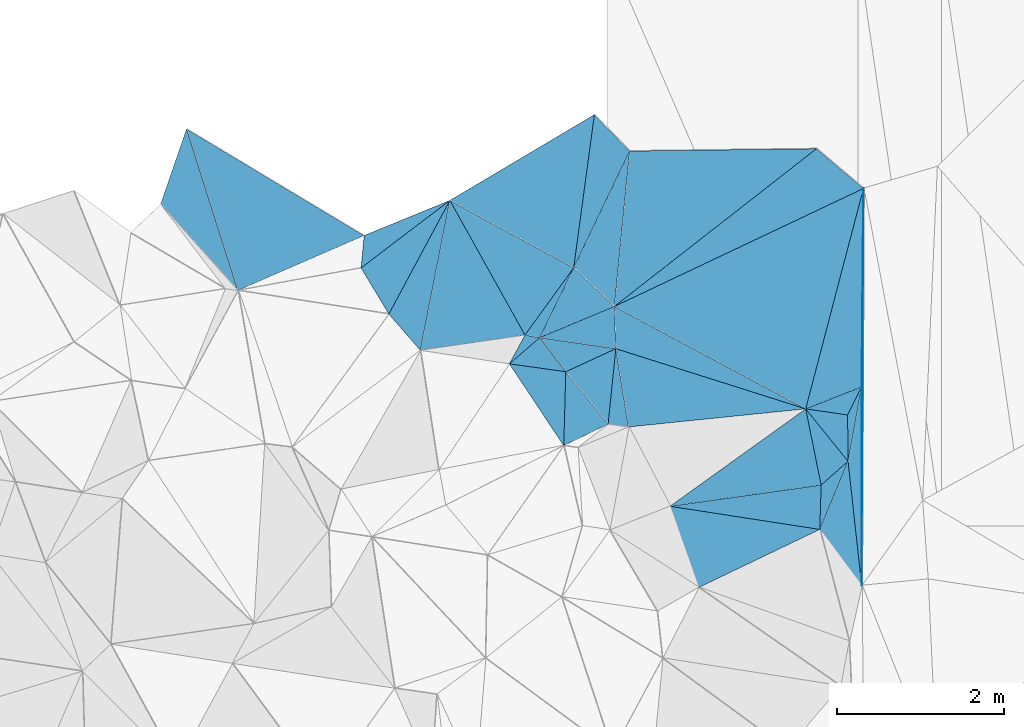
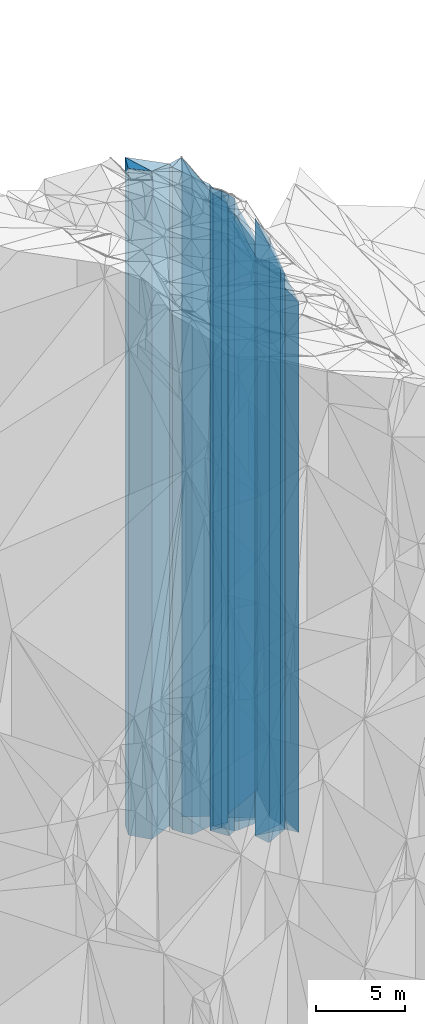
# One storey, part 273 of 275: 37 plates.
"""IFC2X3 building model written with IfcOpenShell, lengths in millimetres."""

from ifc_helpers import new_model, si_unit, frame, origin_with_axes, place, context, subcontext, project, spatial, faceted_brep, material, type_object, element, save


model = new_model("IFC2X3")

# Units and contexts
model_context = context("Model", 3, precision=1e-05, world=origin_with_axes())
body_context = subcontext(model_context, "Body", "Model", "MODEL_VIEW")
ifc_project = project(units=[si_unit("LENGTHUNIT", "METRE", prefix="MILLI"), si_unit("AREAUNIT", "SQUARE_METRE"), si_unit("VOLUMEUNIT", "CUBIC_METRE"), si_unit("MASSUNIT", "GRAM", prefix="KILO"), si_unit("TIMEUNIT", "SECOND"), si_unit("PLANEANGLEUNIT", "RADIAN"), si_unit("SOLIDANGLEUNIT", "STERADIAN"), si_unit("THERMODYNAMICTEMPERATUREUNIT", "DEGREE_CELSIUS"), si_unit("LUMINOUSINTENSITYUNIT", "LUMEN")], contexts=[model_context])

# Site, building, storey
site_placement = place(None, origin_with_axes())
site = spatial("IfcSite", under=ifc_project, at=site_placement, CompositionType="ELEMENT")
building_placement = place(site_placement, origin_with_axes())
building = spatial("IfcBuilding", under=site, at=building_placement, Name="Undefined", CompositionType="ELEMENT")
storey_placement = place(building_placement, origin_with_axes())
storey = spatial("IfcBuildingStorey", under=building, at=storey_placement, Name="Undefined", CompositionType="ELEMENT", Elevation=0.0)

# Plates
ifc_material = material()
plate_type_1 = type_object("IfcPlateType", PredefinedType="NOTDEFINED")
plate_1_placement = place(storey_placement, frame((-98121.5474318515, 131950.732963402, 26824.0), z_axis=(-0.999534183592398, 0.0305191059875469, 0.0), x_axis=(0.0305191059875562, 0.999534183592397, 0.0)))
element("IfcPlate", 1, at=plate_1_placement, inside=storey, type_object=plate_type_1, material=ifc_material, Name="00", context=body_context, shape_type="Brep", body=[
    faceted_brep([(1.45519152283669e-11, -18996.0, 0.0), (222.635833740249, -23306.0, 1803.25634765625), (222.635833740249, 18996.0, 1803.25634765625), (1.45519152283669e-11, 18996.0, 0.0), (532.259338378906, -19006.0, -1.03318598121405e-09), (532.259338378906, 18996.0, -1.03318598121405e-09)], [[[0, 1, 2, 3]], [[1, 4, 5, 2]], [[4, 0, 3, 5]], [[5, 3, 2]], [[4, 1, 0]]]),
])
plate_type_2 = type_object("IfcPlateType", PredefinedType="NOTDEFINED")
plate_2_placement = place(storey_placement, frame((-98121.5474318515, 131950.732963402, 26824.0), z_axis=(-0.152764910053811, -0.988262557348122, 0.0), x_axis=(-0.988262557348123, 0.152764910053806, 0.0)))
element("IfcPlate", 2, at=plate_2_placement, inside=storey, type_object=plate_type_2, material=ifc_material, Name="00", context=body_context, shape_type="Brep", body=[
    faceted_brep([(1.45519152283669e-11, -18996.0, 0.0), (1328.7667236328, -22476.0, 910.482849121094), (1328.7667236328, 18996.0, 910.482849121094), (1.45519152283669e-11, 18996.0, 0.0), (1816.94799804688, -23306.0, 8.73114913702011e-11), (1816.94799804688, 18996.0, 8.73114913702011e-11)], [[[0, 1, 2, 3]], [[1, 4, 5, 2]], [[4, 0, 3, 5]], [[5, 3, 2]], [[4, 1, 0]]]),
])
plate_type_3 = type_object("IfcPlateType", PredefinedType="NOTDEFINED")
plate_3_placement = place(storey_placement, frame((-101166.01981522, 133841.020747551, 29644.0), z_axis=(-0.138726250945665, -0.990330766612126, 0.0), x_axis=(-0.990330766612127, 0.138726250945655, 0.0)))
element("IfcPlate", 3, at=plate_3_placement, inside=storey, type_object=plate_type_3, material=ifc_material, Name="00", context=body_context, shape_type="Brep", body=[
    faceted_brep([(0.0, -21816.0, -2.18278728425503e-11), (-99.0270233154297, -22096.0, 880.110046386733), (-99.0270233154297, 21816.0, 880.110046386733), (-1.45519152283669e-11, 21816.0, 1.45519152283669e-11), (682.641906738296, -22166.0, 4.43833414465189e-09), (682.641906738296, 21816.0, 4.43833414465189e-09)], [[[0, 1, 2, 3]], [[1, 4, 5, 2]], [[4, 0, 3, 5]], [[5, 3, 2]], [[4, 1, 0]]]),
])
plate_type_4 = type_object("IfcPlateType", PredefinedType="NOTDEFINED")
plate_4_placement = place(storey_placement, frame((-99917.1690995878, 132228.298858922, 26829.0), z_axis=(-0.139068254049693, 0.990282798353869, 0.0), x_axis=(0.990282798353869, 0.139068254049695, 0.0)))
element("IfcPlate", 4, at=plate_4_placement, inside=storey, type_object=plate_type_4, material=ifc_material, Name="00", context=body_context, shape_type="Brep", body=[
    faceted_brep([(-1.45519152283669e-11, -23301.0, 2.91038304567337e-11), (1773.3497314453, -19031.0, 930.0166015625), (1773.3497314453, 19001.0, 930.0166015625), (-1.45519152283669e-11, 19001.0, 2.91038304567337e-11), (1829.64477539061, -19001.0, -7.71251507103443e-09), (1829.64477539061, 19001.0, -7.71251507103443e-09)], [[[0, 1, 2, 3]], [[1, 4, 5, 2]], [[4, 0, 3, 5]], [[5, 3, 2]], [[4, 1, 0]]]),
])
plate_type_5 = type_object("IfcPlateType", PredefinedType="NOTDEFINED")
plate_5_placement = place(storey_placement, frame((-97782.8954813974, 132767.442738324, 26069.0), z_axis=(0.661910276065905, -0.749583075074643, 0.0), x_axis=(-0.749583075074636, -0.661910276065912, 0.0)))
element("IfcPlate", 5, at=plate_5_placement, inside=storey, type_object=plate_type_5, material=ifc_material, Name="00", context=body_context, shape_type="Brep", body=[
    faceted_brep([(2.91038304567337e-11, -18241.0, -1.45519152283669e-11), (794.436340332033, -19751.0, 388.034606933594), (794.436340332033, 18241.0, 388.034606933594), (0.0, 18241.0, 0.0), (430.116271972644, -19761.0, 5.79166226089001e-09), (430.116271972644, 18241.0, 5.79166226089001e-09)], [[[0, 1, 2, 3]], [[1, 4, 5, 2]], [[4, 0, 3, 5]], [[5, 3, 2]], [[4, 1, 0]]]),
])
plate_type_6 = type_object("IfcPlateType", PredefinedType="NOTDEFINED")
plate_6_placement = place(storey_placement, frame((-97782.8954813974, 132767.442738324, 26069.0), z_axis=(-0.999958933344225, -0.00906265000312683, 0.0), x_axis=(-0.00906265000311493, 0.999958933344225, 0.0)))
element("IfcPlate", 6, at=plate_6_placement, inside=storey, type_object=plate_type_6, material=ifc_material, Name="00", context=body_context, shape_type="Brep", body=[
    faceted_brep([(2.91038304567337e-11, -18241.0, -1.45519152283669e-11), (633.025634765625, -19791.0, 501.775421142593), (633.025634765625, 18241.0, 501.775421142593), (0.0, 18241.0, 0.0), (555.427734375029, -18321.0, -2.9394868761301e-09), (555.427734375029, 18241.0, -2.9394868761301e-09)], [[[0, 1, 2, 3]], [[1, 4, 5, 2]], [[4, 0, 3, 5]], [[5, 3, 2]], [[4, 1, 0]]]),
])
plate_type_7 = type_object("IfcPlateType", PredefinedType="NOTDEFINED")
plate_7_placement = place(storey_placement, frame((-98121.5474318515, 131950.732963402, 25978.0), z_axis=(0.801619117841387, 0.597835085881714, 0.0), x_axis=(0.597835085881705, -0.801619117841394, 0.0)))
element("IfcPlate", 7, at=plate_7_placement, inside=storey, type_object=plate_type_7, material=ifc_material, Name="00", context=body_context, shape_type="Brep", body=[
    faceted_brep([(-2.91038304567337e-11, -19842.0, 5.74118530494161e-12), (-452.232147216826, -18332.0, 759.727661132818), (-452.232147216826, 18150.0, 759.727661132818), (1.45519152283669e-11, 18150.0, 1.45519152283669e-11), (840.077392578067, -18150.0, -1.20206777864951e-09), (840.077392578067, 18150.0, -1.20206777864951e-09)], [[[0, 1, 2, 3]], [[1, 4, 5, 2]], [[4, 0, 3, 5]], [[5, 3, 2]], [[4, 1, 0]]]),
])
plate_type_8 = type_object("IfcPlateType", PredefinedType="NOTDEFINED")
plate_8_placement = place(storey_placement, frame((-100566.438423901, 134117.068126065, 28964.0), z_axis=(0.994857020313297, -0.101289235031902, 0.0), x_axis=(-0.101289235031895, -0.994857020313298, 0.0)))
element("IfcPlate", 8, at=plate_8_placement, inside=storey, type_object=plate_type_8, material=ifc_material, Name="00", context=body_context, shape_type="Brep", body=[
    faceted_brep([(2.91038304567337e-11, -21136.0, 1.45519152283669e-11), (918.194641113267, -21376.0, 246.817047119141), (918.194641113267, 21136.0, 246.817047119141), (-7.27595761418343e-12, 21136.0, 0.0), (909.175476074219, -22166.0, 5.02041075378656e-09), (909.175476074219, 21136.0, 5.02041075378656e-09)], [[[0, 1, 2, 3]], [[1, 4, 5, 2]], [[4, 0, 3, 5]], [[5, 3, 2]], [[4, 1, 0]]]),
])
plate_type_9 = type_object("IfcPlateType", PredefinedType="NOTDEFINED")
plate_9_placement = place(storey_placement, frame((-100566.438423901, 134117.068126065, 28964.0), z_axis=(0.418205603024499, -0.908352395053217, 0.0), x_axis=(-0.908352395053213, -0.418205603024508, 0.0)))
element("IfcPlate", 9, at=plate_9_placement, inside=storey, type_object=plate_type_9, material=ifc_material, Name="00", context=body_context, shape_type="Brep", body=[
    faceted_brep([(2.91038304567337e-11, -21136.0, 1.45519152283669e-11), (461.916687011711, -22166.0, 783.091918945283), (461.916687011711, 21136.0, 783.091918945283), (-7.27595761418343e-12, 21136.0, 0.0), (660.075744628914, -22496.0, 2.61934474110603e-09), (660.075744628914, 21136.0, 2.61934474110603e-09)], [[[0, 1, 2, 3]], [[1, 4, 5, 2]], [[4, 0, 3, 5]], [[5, 3, 2]], [[4, 1, 0]]]),
])
plate_type_10 = type_object("IfcPlateType", PredefinedType="NOTDEFINED")
plate_10_placement = place(storey_placement, frame((-100658.52811006, 133212.568546351, 29479.0), z_axis=(-0.778004293593025, -0.628258958671357, 0.0), x_axis=(-0.62825895867135, 0.778004293593031, 0.0)))
element("IfcPlate", 10, at=plate_10_placement, inside=storey, type_object=plate_type_10, material=ifc_material, Name="00", context=body_context, shape_type="Brep", body=[
    faceted_brep([(-2.91038304567337e-11, -21651.0, 7.27595761418343e-12), (134.072036743135, -22261.0, 574.912780761726), (134.072036743135, 21651.0, 574.912780761726), (-2.91038304567337e-11, 21651.0, 7.27595761418343e-12), (807.774719238252, -21981.0, -2.85945134237409e-09), (807.774719238252, 21651.0, -2.85945134237409e-09)], [[[0, 1, 2, 3]], [[1, 4, 5, 2]], [[4, 0, 3, 5]], [[5, 3, 2]], [[4, 1, 0]]]),
])
plate_type_11 = type_object("IfcPlateType", PredefinedType="NOTDEFINED")
plate_11_placement = place(storey_placement, frame((-97619.7549121552, 133659.622739595, 26009.0), z_axis=(0.894653739119455, -0.446760212059645, 0.0), x_axis=(-0.446760212059642, -0.894653739119456, 0.0)))
element("IfcPlate", 11, at=plate_11_placement, inside=storey, type_object=plate_type_11, material=ifc_material, Name="00", context=body_context, shape_type="Brep", body=[
    faceted_brep([(1.45519152283669e-11, -18181.0, -2.91038304567337e-11), (871.07690429689, -18301.0, 252.636199951143), (871.07690429689, 18181.0, 252.636199951143), (1.45519152283669e-11, 18181.0, -2.91038304567337e-11), (376.430603027358, -18381.0, -3.28873284161091e-09), (376.430603027358, 18181.0, -3.28873284161091e-09)], [[[0, 1, 2, 3]], [[1, 4, 5, 2]], [[4, 0, 3, 5]], [[5, 3, 2]], [[4, 1, 0]]]),
])
plate_type_12 = type_object("IfcPlateType", PredefinedType="NOTDEFINED")
plate_12_placement = place(storey_placement, frame((-100582.733736698, 134623.757836619, 26844.0), z_axis=(0.999483257120555, 0.0321437200038698, 0.0), x_axis=(0.0321437200038842, -0.999483257120554, 0.0)))
element("IfcPlate", 12, at=plate_12_placement, inside=storey, type_object=plate_type_12, material=ifc_material, Name="00", context=body_context, shape_type="Brep", body=[
    faceted_brep([(-2.91038304567337e-11, -23306.0, -1.45519152283669e-11), (1300.91296386713, -19016.0, 2251.69384765625), (1300.91296386713, 19016.0, 2251.69384765625), (0.0, 19016.0, -2.91038304567337e-11), (506.951660156221, -23256.0, -1.25146470963955e-09), (506.951660156221, 19016.0, -1.25146470963955e-09)], [[[0, 1, 2, 3]], [[1, 4, 5, 2]], [[4, 0, 3, 5]], [[5, 3, 2]], [[4, 1, 0]]]),
])
plate_type_13 = type_object("IfcPlateType", PredefinedType="NOTDEFINED")
plate_13_placement = place(storey_placement, frame((-97782.8954813974, 132767.442738324, 25978.0), z_axis=(0.994028888740654, 0.10911722297154, 0.0), x_axis=(0.109117222971529, -0.994028888740655, 0.0)))
element("IfcPlate", 13, at=plate_13_placement, inside=storey, type_object=plate_type_13, material=ifc_material, Name="00", context=body_context, shape_type="Brep", body=[
    faceted_brep([(-2.91038304567337e-11, -18332.0, 0.0), (-869.051269531279, -18212.0, 259.518646240234), (-869.051269531279, 18150.0, 259.518646240234), (1.45519152283669e-11, 18150.0, 1.45519152283669e-11), (1499.08300781247, -18150.0, -5.45696821063757e-09), (1499.08300781247, 18150.0, -5.45696821063757e-09)], [[[0, 1, 2, 3]], [[1, 4, 5, 2]], [[4, 0, 3, 5]], [[5, 3, 2]], [[4, 1, 0]]]),
])
plate_type_14 = type_object("IfcPlateType", PredefinedType="NOTDEFINED")
plate_14_placement = place(storey_placement, frame((-98290.3871865576, 133395.894939524, 26009.0), z_axis=(0.143867401977837, 0.989596973847509, 0.0), x_axis=(0.989596973847514, -0.143867401977803, 0.0)))
element("IfcPlate", 14, at=plate_14_placement, inside=storey, type_object=plate_type_14, material=ifc_material, Name="00", context=body_context, shape_type="Brep", body=[
    faceted_brep([(0.0, -19851.0, 2.91038304567337e-11), (625.713806152329, -18181.0, 357.466369628935), (625.713806152329, 18181.0, 357.466369628935), (1.45519152283669e-11, 18181.0, -2.91038304567337e-11), (507.740081787095, -18381.0, -2.60479282587767e-09), (507.740081787095, 18181.0, -2.60479282587767e-09)], [[[0, 1, 2, 3]], [[1, 4, 5, 2]], [[4, 0, 3, 5]], [[5, 3, 2]], [[4, 1, 0]]]),
])
plate_type_15 = type_object("IfcPlateType", PredefinedType="NOTDEFINED")
plate_15_placement = place(storey_placement, frame((-97598.4704620426, 136037.324144772, 26040.5), z_axis=(0.428078408955571, -0.903741597906208, 0.0), x_axis=(-0.903741597906208, -0.428078408955572, 0.0)))
element("IfcPlate", 15, at=plate_15_placement, inside=storey, type_object=plate_type_15, material=ifc_material, Name="00", context=body_context, shape_type="Brep", body=[
    faceted_brep([(-7.27595761418343e-12, -18212.5, 0.0), (1756.05273437498, -19819.5, 2090.9748535156), (1756.05273437498, 18212.5, 2090.9748535156), (-7.27595761418343e-12, 18212.5, 0.0), (3302.12011718749, -24109.5, -2.91038304567337e-08), (3302.12011718749, 18212.5, -2.91038304567337e-08)], [[[0, 1, 2, 3]], [[1, 4, 5, 2]], [[4, 0, 3, 5]], [[5, 3, 2]], [[4, 1, 0]]]),
])
plate_type_16 = type_object("IfcPlateType", PredefinedType="NOTDEFINED")
plate_16_placement = place(storey_placement, frame((-98105.3033525816, 132482.744363551, 26069.0), z_axis=(-0.661910276065905, 0.749583075074643, 0.0), x_axis=(0.749583075074651, 0.661910276065895, 0.0)))
element("IfcPlate", 16, at=plate_16_placement, inside=storey, type_object=plate_type_16, material=ifc_material, Name="00", context=body_context, shape_type="Brep", body=[
    faceted_brep([(7.27595761418343e-12, -19761.0, -2.91038304567337e-11), (465.688049316428, -19791.0, 806.991088867158), (465.688049316428, 18241.0, 806.991088867158), (0.0, 18241.0, 0.0), (430.116271972664, -18241.0, 5.73345459997654e-09), (430.116271972644, 18241.0, 5.79166226089001e-09)], [[[0, 1, 2, 3]], [[1, 4, 5, 2]], [[4, 0, 3, 5]], [[5, 3, 2]], [[4, 1, 0]]]),
])
plate_type_17 = type_object("IfcPlateType", PredefinedType="NOTDEFINED")
plate_17_placement = place(storey_placement, frame((-100566.438423901, 134117.068126065, 28964.0), z_axis=(-0.999483257120555, -0.0321437200038698, 0.0), x_axis=(-0.0321437200038805, 0.999483257120554, 0.0)))
element("IfcPlate", 17, at=plate_17_placement, inside=storey, type_object=plate_type_17, material=ifc_material, Name="00", context=body_context, shape_type="Brep", body=[
    faceted_brep([(2.91038304567337e-11, -21136.0, 1.45519152283669e-11), (161.948379516602, -22156.0, 906.792541503921), (161.948379516602, 21136.0, 906.792541503921), (-7.27595761418343e-12, 21136.0, 0.0), (506.95166015625, -21186.0, -1.22236087918282e-09), (506.95166015625, 21136.0, -1.22236087918282e-09)], [[[0, 1, 2, 3]], [[1, 4, 5, 2]], [[4, 0, 3, 5]], [[5, 3, 2]], [[4, 1, 0]]]),
])
plate_type_18 = type_object("IfcPlateType", PredefinedType="NOTDEFINED")
plate_18_placement = place(storey_placement, frame((-100413.893981991, 133178.595860496, 26844.0), z_axis=(-0.101798692024404, 0.994805019238504, 0.0), x_axis=(0.994805019238504, 0.101798692024408, 0.0)))
element("IfcPlate", 18, at=plate_18_placement, inside=storey, type_object=plate_type_18, material=ifc_material, Name="00", context=body_context, shape_type="Brep", body=[
    faceted_brep([(-1.45519152283669e-11, -23496.0, -2.91038304567337e-11), (-56.2167282104492, -23256.0, 949.125732421933), (-56.2167282104492, 19016.0, 949.125732421933), (0.0, 19016.0, -2.91038304567337e-11), (2134.59594726564, -19016.0, 5.355104804039e-09), (2134.59594726563, 19016.0, 5.29689714312553e-09)], [[[0, 1, 2, 3]], [[1, 4, 5, 2]], [[4, 0, 3, 5]], [[5, 3, 2]], [[4, 1, 0]]]),
])
plate_type_19 = type_object("IfcPlateType", PredefinedType="NOTDEFINED")
plate_19_placement = place(storey_placement, frame((-101071.251231754, 135085.656805035, 29184.0), z_axis=(0.809292046734251, -0.587406488807102, 0.0), x_axis=(-0.5874064888071, -0.809292046734252, 0.0)))
element("IfcPlate", 19, at=plate_19_placement, inside=storey, type_object=plate_type_19, material=ifc_material, Name="00", context=body_context, shape_type="Brep", body=[
    faceted_brep([(0.0, -21356.0, 0.0), (915.372375488289, -21936.0, 161.843780517578), (915.372375488289, 21356.0, 161.843780517578), (0.0, 21356.0, 0.0), (994.786437988274, -22146.0, 8.78935679793358e-09), (994.786437988274, 21356.0, 8.78935679793358e-09)], [[[0, 1, 2, 3]], [[1, 4, 5, 2]], [[4, 0, 3, 5]], [[5, 3, 2]], [[4, 1, 0]]]),
])
plate_type_20 = type_object("IfcPlateType", PredefinedType="NOTDEFINED")
plate_20_placement = place(storey_placement, frame((-100566.438423901, 134117.068126065, 28964.0), z_axis=(-0.144078985958425, -0.989566190714493, 0.0), x_axis=(-0.989566190714492, 0.144078985958431, 0.0)))
element("IfcPlate", 20, at=plate_20_placement, inside=storey, type_object=plate_type_20, material=ifc_material, Name="00", context=body_context, shape_type="Brep", body=[
    faceted_brep([(2.91038304567337e-11, -21136.0, 1.45519152283669e-11), (553.552856445298, -22496.0, 359.554229736357), (553.552856445298, 21136.0, 359.554229736357), (-7.27595761418343e-12, 21136.0, 0.0), (921.140624999985, -22156.0, -2.00816430151463e-09), (921.140624999985, 21136.0, -2.00816430151463e-09)], [[[0, 1, 2, 3]], [[1, 4, 5, 2]], [[4, 0, 3, 5]], [[5, 3, 2]], [[4, 1, 0]]]),
])
plate_type_21 = type_object("IfcPlateType", PredefinedType="NOTDEFINED")
plate_21_placement = place(storey_placement, frame((-102908.882277268, 134098.179139179, 29579.0), z_axis=(-0.144023847039192, 0.989574217269241, 0.0), x_axis=(0.989574217269243, 0.144023847039183, 0.0)))
element("IfcPlate", 21, at=plate_21_placement, inside=storey, type_object=plate_type_21, material=ifc_material, Name="00", context=body_context, shape_type="Brep", body=[
    faceted_brep([(-2.91038304567337e-11, -23271.0, 0.0), (608.768554687515, -23391.0, 1726.81811523438), (608.768554687515, 21751.0, 1726.81811523438), (2.18278728425503e-11, 21751.0, -2.91038304567337e-11), (1266.4912109375, -21751.0, 8.49831849336624e-09), (1266.4912109375, 21751.0, 8.49831849336624e-09)], [[[0, 1, 2, 3]], [[1, 4, 5, 2]], [[4, 0, 3, 5]], [[5, 3, 2]], [[4, 1, 0]]]),
])
plate_type_22 = type_object("IfcPlateType", PredefinedType="NOTDEFINED")
plate_22_placement = place(storey_placement, frame((-101842.061117764, 133935.721102646, 29474.0), z_axis=(0.138726250945665, 0.990330766612126, 0.0), x_axis=(0.990330766612123, -0.138726250945685, 0.0)))
element("IfcPlate", 22, at=plate_22_placement, inside=storey, type_object=plate_type_22, material=ifc_material, Name="00", context=body_context, shape_type="Brep", body=[
    faceted_brep([(-1.45519152283669e-11, -22336.0, 0.0), (317.00366210936, -21646.0, 361.536529541001), (317.00366210936, 21646.0, 361.536529541001), (0.0, 21646.0, -2.18278728425503e-11), (682.641906738267, -21986.0, 4.40923031419516e-09), (682.641906738267, 21646.0, 4.40923031419516e-09)], [[[0, 1, 2, 3]], [[1, 4, 5, 2]], [[4, 0, 3, 5]], [[5, 3, 2]], [[4, 1, 0]]]),
])
plate_type_23 = type_object("IfcPlateType", PredefinedType="NOTDEFINED")
plate_23_placement = place(storey_placement, frame((-101477.968015816, 134249.785129739, 29474.0), z_axis=(-0.170841814937067, -0.985298469636997, 0.0), x_axis=(-0.985298469636999, 0.170841814937059, 0.0)))
element("IfcPlate", 23, at=plate_23_placement, inside=storey, type_object=plate_type_23, material=ifc_material, Name="00", context=body_context, shape_type="Brep", body=[
    faceted_brep([(0.0, -21646.0, 1.45519152283669e-11), (305.085113525405, -22336.0, 371.649139404297), (305.085113525405, 21646.0, 371.649139404297), (0.0, 21646.0, -2.18278728425503e-11), (180.277557373076, -21856.0, -1.17870513349772e-09), (180.277557373076, 21646.0, -1.17870513349772e-09)], [[[0, 1, 2, 3]], [[1, 4, 5, 2]], [[4, 0, 3, 5]], [[5, 3, 2]], [[4, 1, 0]]]),
])
plate_type_24 = type_object("IfcPlateType", PredefinedType="NOTDEFINED")
plate_24_placement = place(storey_placement, frame((-102555.163622691, 135894.671029894, 30399.0), z_axis=(0.605511494754839, -0.795836559677777, 0.0), x_axis=(-0.795836559677778, -0.605511494754839, 0.0)))
element("IfcPlate", 24, at=plate_24_placement, inside=storey, type_object=plate_type_24, material=ifc_material, Name="00", context=body_context, shape_type="Brep", body=[
    faceted_brep([(-2.18278728425503e-11, -22571.0, 0.0), (1407.08532714845, -22641.0, 641.101196289063), (1407.08532714845, 22571.0, 641.101196289063), (-6.02540239924565e-12, 22571.0, -2.91038304567337e-11), (1336.45056152343, -22741.0, 1.86264514923096e-09), (1336.45056152343, 22571.0, 1.86264514923096e-09)], [[[0, 1, 2, 3]], [[1, 4, 5, 2]], [[4, 0, 3, 5]], [[5, 3, 2]], [[4, 1, 0]]]),
])
plate_type_25 = type_object("IfcPlateType", PredefinedType="NOTDEFINED")
plate_25_placement = place(storey_placement, frame((-105095.590954133, 134815.120672726, 30629.0), z_axis=(-0.952991695260261, -0.302996417082734, 0.0), x_axis=(-0.302996417082751, 0.952991695260256, 0.0)))
element("IfcPlate", 25, at=plate_25_placement, inside=storey, type_object=plate_type_25, material=ifc_material, Name="00", context=body_context, shape_type="Brep", body=[
    faceted_brep([(-1.45519152283669e-11, -22921.0, -5.82076609134674e-11), (1265.68395996091, -22801.0, 570.389465332031), (1265.68395996091, 22801.0, 570.389465332031), (-7.27595761418343e-12, 22801.0, 0.0), (2031.94482421872, -22921.0, 1.27765815705061e-08), (2031.94482421872, 22801.0, 1.27765815705061e-08)], [[[0, 1, 2, 3]], [[1, 4, 5, 2]], [[4, 0, 3, 5]], [[5, 3, 2]], [[4, 1, 0]]]),
])
plate_type_26 = type_object("IfcPlateType", PredefinedType="NOTDEFINED")
plate_26_placement = place(storey_placement, frame((-102555.163622691, 135894.671029894, 30399.0), z_axis=(0.379539196103224, -0.92517565825162, 0.0), x_axis=(-0.925175658251617, -0.379539196103232, 0.0)))
element("IfcPlate", 26, at=plate_26_placement, inside=storey, type_object=plate_type_26, material=ifc_material, Name="00", context=body_context, shape_type="Brep", body=[
    faceted_brep([(-2.18278728425503e-11, -22571.0, 0.0), (1291.15014648439, -22741.0, 345.009155273408), (1291.15014648439, 22571.0, 345.009155273408), (-6.02540239924565e-12, 22571.0, -2.91038304567337e-11), (1110.40527343751, -22731.0, -1.18161551654339e-08), (1110.40527343751, 22571.0, -1.18161551654339e-08)], [[[0, 1, 2, 3]], [[1, 4, 5, 2]], [[4, 0, 3, 5]], [[5, 3, 2]], [[4, 1, 0]]]),
])
plate_type_27 = type_object("IfcPlateType", PredefinedType="NOTDEFINED")
plate_27_placement = place(storey_placement, frame((-100400.482500608, 136486.574114985, 28924.0), z_axis=(0.901942477092671, -0.431856189044382, 0.0), x_axis=(-0.431856189044368, -0.901942477092677, 0.0)))
element("IfcPlate", 27, at=plate_27_placement, inside=storey, type_object=plate_type_27, material=ifc_material, Name="00", context=body_context, shape_type="Brep", body=[
    faceted_brep([(-7.27595761418343e-12, -21096.0, 0.0), (1758.8594970703, -21226.0, 640.088623046875), (1758.8594970703, 21096.0, 640.088623046875), (0.0, 21096.0, 0.0), (1553.22241210938, -21616.0, 9.05129127204418e-09), (1553.22241210938, 21096.0, 9.05129127204418e-09)], [[[0, 1, 2, 3]], [[1, 4, 5, 2]], [[4, 0, 3, 5]], [[5, 3, 2]], [[4, 1, 0]]]),
])
plate_type_28 = type_object("IfcPlateType", PredefinedType="NOTDEFINED")
plate_28_placement = place(storey_placement, frame((-102555.163622691, 135894.671029894, 30339.0), z_axis=(0.880979798180826, -0.473153881097123, 0.0), x_axis=(-0.473153881097113, -0.880979798180832, 0.0)))
element("IfcPlate", 28, at=plate_28_placement, inside=storey, type_object=plate_type_28, material=ifc_material, Name="00", context=body_context, shape_type="Brep", body=[
    faceted_brep([(0.0, -22631.0, 2.91038304567337e-11), (1750.03637695313, -22511.0, 538.39813232419), (1750.03637695313, 22511.0, 538.39813232419), (0.0, 22511.0, 0.0), (1546.25354003906, -22701.0, -3.98722477257252e-09), (1546.25354003906, 22511.0, -3.98722477257252e-09)], [[[0, 1, 2, 3]], [[1, 4, 5, 2]], [[4, 0, 3, 5]], [[5, 3, 2]], [[4, 1, 0]]]),
])
plate_type_29 = type_object("IfcPlateType", PredefinedType="NOTDEFINED")
plate_29_placement = place(storey_placement, frame((-100823.050988554, 136922.963703535, 29039.0), z_axis=(0.510483989128613, -0.859887258216645, 0.0), x_axis=(-0.859887258216646, -0.510483989128611, 0.0)))
element("IfcPlate", 29, at=plate_29_placement, inside=storey, type_object=plate_type_29, material=ifc_material, Name="00", context=body_context, shape_type="Brep", body=[
    faceted_brep([(-7.27595761418343e-12, -21211.0, 2.91038304567337e-11), (1151.3399658203, -21501.0, 1453.17456054682), (1151.3399658203, 21211.0, 1453.17456054682), (0.0, 21211.0, 1.45519152283669e-11), (2014.34851074217, -23931.0, 4.94765117764473e-09), (2014.34851074217, 21211.0, 4.94765117764473e-09)], [[[0, 1, 2, 3]], [[1, 4, 5, 2]], [[4, 0, 3, 5]], [[5, 3, 2]], [[4, 1, 0]]]),
])
plate_type_30 = type_object("IfcPlateType", PredefinedType="NOTDEFINED")
plate_30_placement = place(storey_placement, frame((-101477.968015816, 134249.785129739, 28989.0), z_axis=(-0.385456948096062, 0.922725821229942, 0.0), x_axis=(0.922725821229945, 0.385456948096055, 0.0)))
element("IfcPlate", 30, at=plate_30_placement, inside=storey, type_object=plate_type_30, material=ifc_material, Name="00", context=body_context, shape_type="Brep", body=[
    faceted_brep([(-2.91038304567337e-11, -22131.0, 1.45519152283669e-11), (697.480651855491, -21551.0, 614.508544921904), (697.480651855491, 21161.0, 614.508544921904), (0.0, 21161.0, -4.54747350886464e-12), (970.20617675782, -21161.0, 0.0), (970.20617675782, 21161.0, 0.0)], [[[0, 1, 2, 3]], [[1, 4, 5, 2]], [[4, 0, 3, 5]], [[5, 3, 2]], [[4, 1, 0]]]),
])
plate_type_31 = type_object("IfcPlateType", PredefinedType="NOTDEFINED")
plate_31_placement = place(storey_placement, frame((-98290.3871865576, 133395.894939524, 26009.0), z_axis=(-0.365971066136888, 0.930626229348082, 0.0), x_axis=(0.930626229348078, 0.365971066136899, 0.0)))
element("IfcPlate", 31, at=plate_31_placement, inside=storey, type_object=plate_type_31, material=ifc_material, Name="00", context=body_context, shape_type="Brep", body=[
    faceted_brep([(0.0, -19851.0, 2.91038304567337e-11), (1610.60253906248, -18244.0, 2204.96191406253), (1610.60253906248, 18181.0, 2204.96191406253), (1.45519152283669e-11, 18181.0, -2.91038304567337e-11), (720.624755859382, -18181.0, 2.88127921521664e-09), (720.624755859382, 18181.0, 2.88127921521664e-09)], [[[0, 1, 2, 3]], [[1, 4, 5, 2]], [[4, 0, 3, 5]], [[5, 3, 2]], [[4, 1, 0]]]),
])
plate_type_32 = type_object("IfcPlateType", PredefinedType="NOTDEFINED")
plate_32_placement = place(storey_placement, frame((-101655.595223525, 134280.584075848, 29184.0), z_axis=(-0.809292046734251, 0.587406488807102, 0.0), x_axis=(0.587406488807114, 0.809292046734241, 0.0)))
element("IfcPlate", 32, at=plate_32_placement, inside=storey, type_object=plate_type_32, material=ifc_material, Name="00", context=body_context, shape_type="Brep", body=[
    faceted_brep([(2.18278728425503e-11, -22146.0, 0.0), (777.855407714887, -23786.0, 1676.138671875), (777.855407714887, 21356.0, 1676.138671875), (0.0, 21356.0, 0.0), (994.786437988303, -21356.0, 8.78935679793358e-09), (994.786437988274, 21356.0, 8.78935679793358e-09)], [[[0, 1, 2, 3]], [[1, 4, 5, 2]], [[4, 0, 3, 5]], [[5, 3, 2]], [[4, 1, 0]]]),
])
plate_type_33 = type_object("IfcPlateType", PredefinedType="NOTDEFINED")
plate_33_placement = place(storey_placement, frame((-105095.590954133, 134815.120672726, 30479.0), z_axis=(-0.3988460149776, 0.917017914948496, 0.0), x_axis=(0.917017914948496, 0.398846014977601, 0.0)))
element("IfcPlate", 33, at=plate_33_placement, inside=storey, type_object=plate_type_33, material=ifc_material, Name="00", context=body_context, shape_type="Brep", body=[
    faceted_brep([(0.0, -23071.0, 1.45519152283669e-11), (207.753753662102, -23071.0, 2021.29626464841), (207.753753662102, 22651.0, 2021.29626464841), (-1.45519152283669e-11, 22651.0, 0.0), (1650.0302734375, -22651.0, -8.44011083245277e-09), (1650.0302734375, 22651.0, -8.44011083245277e-09)], [[[0, 1, 2, 3]], [[1, 4, 5, 2]], [[4, 0, 3, 5]], [[5, 3, 2]], [[4, 1, 0]]]),
])
plate_type_34 = type_object("IfcPlateType", PredefinedType="NOTDEFINED")
plate_34_placement = place(storey_placement, frame((-100582.733736698, 134623.757836619, 26040.5), z_axis=(-0.428078408955571, 0.903741597906208, 0.0), x_axis=(0.90374159790621, 0.428078408955569, 0.0)))
element("IfcPlate", 34, at=plate_34_placement, inside=storey, type_object=plate_type_34, material=ifc_material, Name="00", context=body_context, shape_type="Brep", body=[
    faceted_brep([(-1.45519152283669e-11, -24109.5, 2.91038304567337e-11), (2998.52197265624, -19059.5, 672.134826660185), (2998.52197265624, 18212.5, 672.134826660185), (-7.27595761418343e-12, 18212.5, 0.0), (3302.1201171875, -18212.5, -2.90456227958202e-08), (3302.12011718749, 18212.5, -2.91038304567337e-08)], [[[0, 1, 2, 3]], [[1, 4, 5, 2]], [[4, 0, 3, 5]], [[5, 3, 2]], [[4, 1, 0]]]),
])
plate_type_35 = type_object("IfcPlateType", PredefinedType="NOTDEFINED")
plate_35_placement = place(storey_placement, frame((-97619.7549121552, 133659.622739595, 25978.0), z_axis=(0.999999983313278, 0.000182684000056657, 0.0), x_axis=(0.000182684000058091, -0.999999983313278, 0.0)))
element("IfcPlate", 35, at=plate_35_placement, inside=storey, type_object=plate_type_35, material=ifc_material, Name="00", context=body_context, shape_type="Brep", body=[
    faceted_brep([(2.91038304567337e-11, -18212.0, -1.45519152283669e-11), (-2377.69750976563, -18275.0, 21.7188186645508), (-2377.69750976563, 18150.0, 21.7188186645508), (1.45519152283669e-11, 18150.0, 1.45519152283669e-11), (2382.31201171878, -18150.0, 1.60944182425737e-08), (2382.31201171878, 18150.0, 1.60944182425737e-08)], [[[0, 1, 2, 3]], [[1, 4, 5, 2]], [[4, 0, 3, 5]], [[5, 3, 2]], [[4, 1, 0]]]),
])
plate_type_36 = type_object("IfcPlateType", PredefinedType="NOTDEFINED")
plate_36_placement = place(storey_placement, frame((-100582.733736698, 134623.757836619, 26464.0), z_axis=(-0.615386185894956, 0.788225755865449, 0.0), x_axis=(0.788225755865451, 0.615386185894954, 0.0)))
element("IfcPlate", 36, at=plate_36_placement, inside=storey, type_object=plate_type_36, material=ifc_material, Name="00", context=body_context, shape_type="Brep", body=[
    faceted_brep([(-1.31876731757075e-11, -23686.0, 2.91038304567337e-11), (1290.00646972656, -23556.0, 1356.16491699222), (1290.00646972656, 18636.0, 1356.16491699222), (-1.31876731757075e-11, 18636.0, 2.91038304567337e-11), (3072.93017578124, -18636.0, 3.69909685105085e-08), (3072.93017578124, 18636.0, 3.69909685105085e-08)], [[[0, 1, 2, 3]], [[1, 4, 5, 2]], [[4, 0, 3, 5]], [[5, 3, 2]], [[4, 1, 0]]]),
])
plate_type_37 = type_object("IfcPlateType", PredefinedType="NOTDEFINED")
plate_37_placement = place(storey_placement, frame((-101071.251231754, 135085.656805035, 28924.0), z_axis=(-0.901942477092671, 0.431856189044382, 0.0), x_axis=(0.431856189044376, 0.901942477092674, 0.0)))
element("IfcPlate", 37, at=plate_37_placement, inside=storey, type_object=plate_type_37, material=ifc_material, Name="00", context=body_context, shape_type="Brep", body=[
    faceted_brep([(-2.91038304567337e-11, -21616.0, -7.27595761418343e-12), (1764.33190917967, -21326.0, 569.590026855498), (1764.33190917967, 21096.0, 569.590026855498), (0.0, 21096.0, 0.0), (1553.22241210936, -21096.0, 9.08039510250092e-09), (1553.22241210938, 21096.0, 9.05129127204418e-09)], [[[0, 1, 2, 3]], [[1, 4, 5, 2]], [[4, 0, 3, 5]], [[5, 3, 2]], [[4, 1, 0]]]),
])

save(model, "model.ifc")
